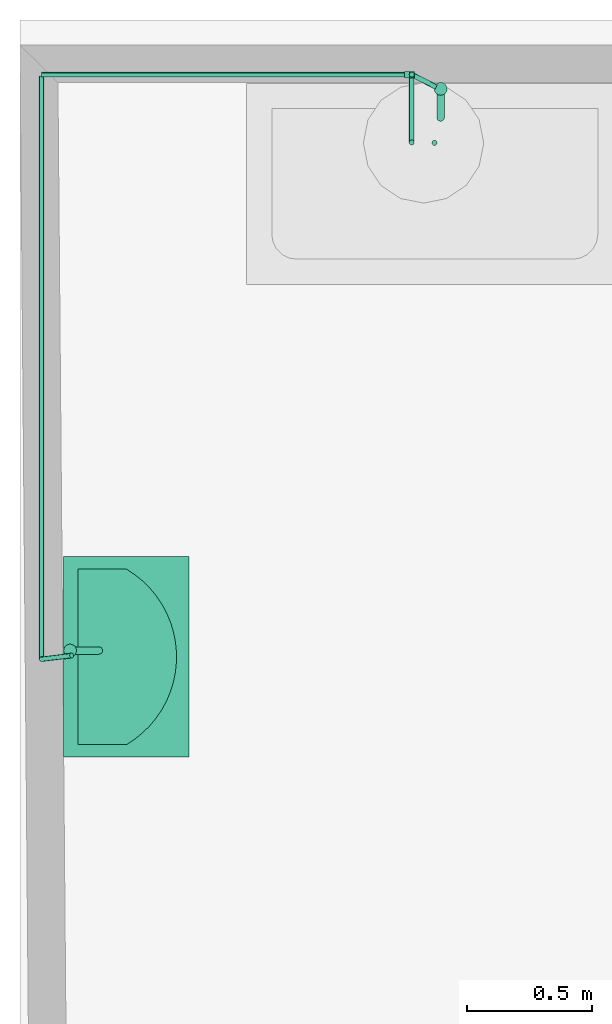
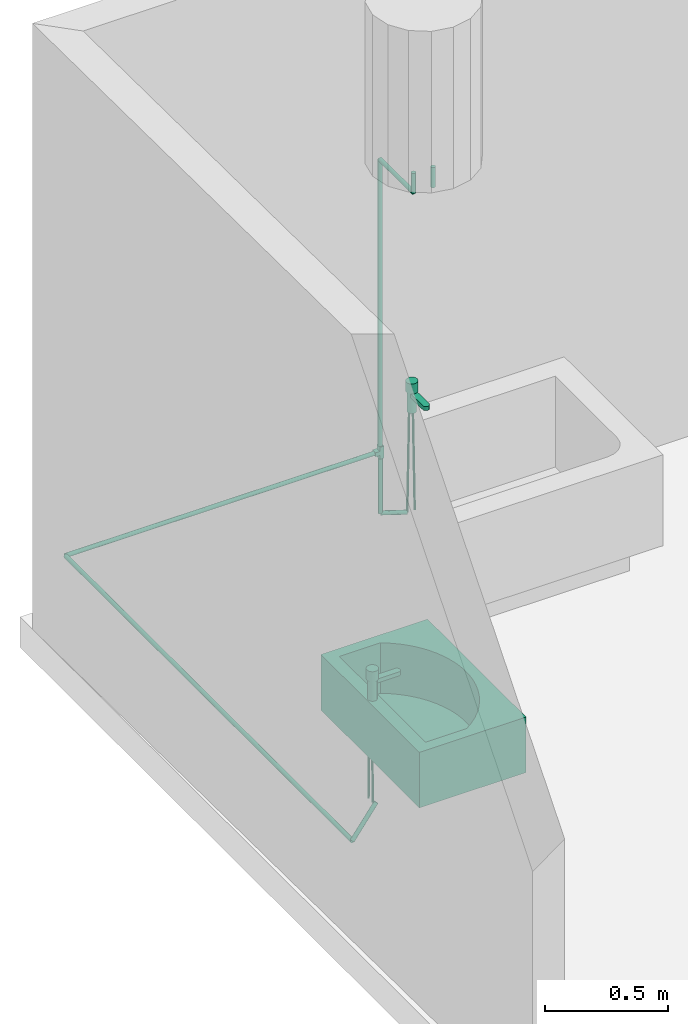
# One storey, part 2 of 3: 9 pipe segments, 2 valves, 1 pipe fitting, 1 sanitary terminal.
"""IFC4 building model written with IfcOpenShell, lengths in metres."""

from ifc_helpers import new_model, entity, si_unit, converted_unit, frame, frame_2d, origin_with_axes, origin_2d, origin_2d_with_axis, place, context, subcontext, project, spatial, line, arc, indexed_curve, circle_curve, circle, outline, extrude, source, transform, mapped, material, material_profile, profile_set, profile_usage, type_object, type_shapes, element, save


model = new_model("IFC4")

# Units and contexts
model_context = context("Model", 3, precision=1e-05, world=origin_with_axes())
plan_context = context("Plan", 2, precision=1e-05, world=origin_2d_with_axis())
body_context = subcontext(model_context, "Body", "Model", "MODEL_VIEW")
ifc_project = project(units=[converted_unit("PLANEANGLEUNIT", "degree", entity("IfcReal", 0.0174532925199433), si_unit("PLANEANGLEUNIT", "RADIAN"), dimensions=[0, 0, 0, 0, 0, 0, 0]), si_unit("AREAUNIT", "SQUARE_METRE"), si_unit("VOLUMEUNIT", "CUBIC_METRE"), si_unit("LENGTHUNIT", "METRE")], contexts=[model_context, plan_context])

# Site, building, storey
site_placement = place(None, origin_with_axes())
site = spatial("IfcSite", under=ifc_project, at=site_placement)
building_placement = place(site_placement, origin_with_axes())
building = spatial("IfcBuilding", under=site, at=building_placement, Name="Building")
storey_placement = place(building_placement, origin_with_axes())
storey = spatial("IfcBuildingStorey", under=building, at=storey_placement, Name="Storey")

# Sanitary terminal
sanitary_terminal_type = type_object("IfcSanitaryTerminalType", Name="BAS-01", PredefinedType="WASHHANDBASIN")
shared_shape_1 = source(origin_with_axes(), body_context, "Body", "SweptSolid", [
    extrude(outline(indexed_curve([(0.0, 0.0), (0.5, 0.0), (0.5, 0.800000011920929), (0.0, 0.800000011920929), (0.0, 0.0)]), holes=[indexed_curve([(0.0579999983310699, 0.750000059604645), (0.0579999983310699, 0.0500000007450581), (0.25, 0.0500000007450581), (0.449999988079071, 0.400000035762787), (0.25, 0.750000059604645)], segments=[line(1, 2), line(2, 3), arc(3, 4, 5), line(5, 1)])]), origin_with_axes(), (0.0, 0.0, 1.0), 0.25),
    extrude(outline(indexed_curve([(0.0, 0.800000071525574), (0.5, 0.800000071525574), (0.5, 0.0), (0.0, 0.0), (0.0, 0.800000071525574)])), frame((1.49011611938477e-08, 0.0, -0.0249999761581421), z_axis=(0.0, 0.0, 1.0), x_axis=(1.0, 0.0, 0.0)), (0.0, 0.0, 1.0), 0.025000000372529),
])
type_shapes(sanitary_terminal_type, [shared_shape_1])
sanitary_terminal_placement = place(storey_placement, frame((0.174114212393761, 1.16106617450714, 0.800000011920929), z_axis=(0.0, 0.0, 1.0), x_axis=(1.0, 0.0, 0.0)))
element("IfcSanitaryTerminal", 1, at=sanitary_terminal_placement, inside=storey, type_object=sanitary_terminal_type, Name="BAS-01", context=body_context, shape_type="MappedRepresentation", body=[
    mapped(shared_shape_1, transform((0.0, 0.0, 0.0), x_axis=(1.0, 0.0, 0.0), y_axis=(0.0, 1.0, 0.0), z_axis=(0.0, 0.0, 1.0), scale=1.0)),
])

# Valves
valve_type = type_object("IfcValveType", Name="MIX-40", PredefinedType="FAUCET")
shared_shape_2 = source(origin_with_axes(), body_context, "Body", "SweptSolid", [
    extrude(outline(circle_curve(frame_2d((1.49011611938477e-08, 0.0)), 0.0199999808298798)), frame((-5.59091567993164e-05, 0.000753998756408691, 0.0), z_axis=(0.0, 0.0, 1.0), x_axis=(1.0, 0.0, 0.0)), (0.0, 0.0, 1.0), 0.100000001490116),
    extrude(outline(indexed_curve([(0.00324422121047974, 0.00130987167358398), (0.0117492079734802, 0.0163098722696304), (0.00324422121047974, 0.0313098728656769), (0.103244222700596, 0.0313098728656769), (0.118292987346649, 0.0163098722696304), (0.103244222700596, 0.00130987167358398)], segments=[arc(1, 2, 3), line(3, 4), arc(4, 5, 6), line(6, 1)])), frame((0.010841965675354, -0.0155558586120605, 0.0799999237060547), z_axis=(0.0, 0.0, 1.0), x_axis=(1.0, 0.0, 0.0)), (0.0, 0.0, 1.0), 0.0199999995529652),
    extrude(outline(circle_curve(frame_2d((1.90300948332833e-08, 0.0)), 0.0255417361909336)), frame((-5.59091567993164e-05, 0.000753998756408691, 0.0999999046325684), z_axis=(0.0, 0.0, 1.0), x_axis=(1.0, 0.0, 0.0)), (0.0, 0.0, 1.0), 0.0500000007450581),
    extrude(outline(circle_curve(origin_2d(), 0.00499999520746994)), frame((-0.00792002760123145, 0.0188064571733357, -0.499757409095764), z_axis=(6.86853392448463e-10, -0.0174524057656526, 0.999847710132599), x_axis=(0.99999999999999, 2.38418571996135e-07, 3.4746536758945e-09)), (0.0, 0.0, 1.0), 0.5),
    extrude(outline(circle_curve(origin_2d(), 0.00499999520746994)), frame((-0.00792002607290776, -0.0161575082426189, -0.499989211559296), z_axis=(-3.9132113163285e-09, 0.0174524057656525, 0.999847710132599), x_axis=(0.99999999999999, 2.38418571996135e-07, -2.47804332609292e-10)), (0.0, 0.0, 1.0), 0.5),
])
type_shapes(valve_type, [shared_shape_2])
for number, where, z_axis, x_axis, name in (
    (2, (0.199711859226227, 1.58566761016846, 1.04999995231628), (0.0, 0.0, 1.0), (1.0, 0.0, 0.0), "MIX-40"),
    (3, (1.67619979381561, 3.82538795471191, 0.599903702735901), (0.0, 0.0, 1.0), (7.54979012640431e-08, -0.999999999999997, 0.0), "MIX-40"),
):
    element("IfcValve", number, at=place(storey_placement, frame(where, z_axis=z_axis, x_axis=x_axis)), inside=storey, type_object=valve_type, Name=name, context=body_context, shape_type="MappedRepresentation", body=[
        mapped(shared_shape_2, transform((0.0, 0.0, 0.0), x_axis=(1.0, 0.0, 0.0), y_axis=(0.0, 1.0, 0.0), z_axis=(0.0, 0.0, 1.0), scale=1.0)),
    ])

# Pipe segments
ifc_material_1 = material(Name="PPE-20H", Category="plumbing")
ifc_material_profile_1 = material_profile(ifc_material_1, circle(Radius=0.00999999977648258, kind="CURVE"))
ifc_profile_set_1 = profile_set([ifc_material_profile_1])
ifc_profile_usage_1 = profile_usage(ifc_profile_set_1, cardinal=5)
pipe_segment_type_1 = type_object("IfcPipeSegmentType", Name="PIP-20H", PredefinedType="RIGIDSEGMENT", material=ifc_profile_set_1)
pipe_segment_1_placement = place(storey_placement, frame((1.56147718429565, 3.6121072769165, 1.95161426067352), z_axis=(-8.74227907843299e-08, -8.74227694680478e-08, -0.999999999999992), x_axis=(-0.999999999999992, 8.74227765734752e-08, 8.74227765734752e-08)))
element("IfcPipeSegment", 4, at=pipe_segment_1_placement, inside=storey, type_object=pipe_segment_type_1, material=ifc_profile_usage_1, Name="20", context=body_context, shape_type="SweptSolid", body=[
    extrude(circle(Radius=0.00999999977648258, kind="CURVE"), origin_with_axes(), (0.0, 0.0, 1.0), 0.100000022165475),
])
ifc_profile_usage_2 = profile_usage(ifc_profile_set_1, cardinal=5)
pipe_segment_2_placement = place(storey_placement, frame((1.56147718429565, 3.6121072769165, 1.85161423683167), z_axis=(-8.74227765734753e-08, 0.999999999999993, 7.54979012640428e-08), x_axis=(-0.999999999999992, -8.74227765734752e-08, 8.74227836789026e-08)))
element("IfcPipeSegment", 5, at=pipe_segment_2_placement, inside=storey, type_object=pipe_segment_type_1, material=ifc_profile_usage_2, Name="20", context=body_context, shape_type="SweptSolid", body=[
    extrude(circle(Radius=0.00999999977648258, kind="CURVE"), origin_with_axes(), (0.0, 0.0, 1.0), 0.269999981081044),
])
ifc_profile_usage_3 = profile_usage(ifc_profile_set_1, cardinal=5)
pipe_segment_3_placement = place(storey_placement, frame((1.56147718429565, 3.88210725784302, 1.85161423683167), z_axis=(-1.50995802528084e-07, -8.74227836789019e-08, -0.999999999999985), x_axis=(-0.999999999999985, 8.74227836789019e-08, 1.50995802528084e-07)))
element("IfcPipeSegment", 6, at=pipe_segment_3_placement, inside=storey, type_object=pipe_segment_type_1, material=ifc_profile_usage_3, Name="20", context=body_context, shape_type="SweptSolid", body=[
    extrude(circle(Radius=0.00999999977648258, kind="CURVE"), origin_with_axes(), (0.0, 0.0, 1.0), 1.41566730292909),
])
ifc_profile_usage_4 = profile_usage(ifc_profile_set_1, cardinal=5)
pipe_segment_4_placement = place(storey_placement, frame((1.56292796134949, 3.88210701942444, 0.10009765625), z_axis=(0.889495304304371, -0.456941510654187, -0.00159983172349935), x_axis=(0.456942106713704, 0.889496436818064, -9.80800568786743e-08)))
element("IfcPipeSegment", 7, at=pipe_segment_4_placement, inside=storey, type_object=pipe_segment_type_1, material=ifc_profile_usage_4, Name="20", context=body_context, shape_type="SweptSolid", body=[
    extrude(circle(Radius=0.00999999977648258, kind="CURVE"), origin_with_axes(), (0.0, 0.0, 1.0), 0.108570010969913),
])
ifc_profile_usage_5 = profile_usage(ifc_profile_set_1, cardinal=5)
pipe_segment_5_placement = place(storey_placement, frame((1.53292798995972, 3.8821074962616, 0.405375480651855), z_axis=(-0.999999999999994, -7.54978941586155e-08, 7.54979012640429e-08), x_axis=(7.5497901264043e-08, -0.999999999999995, 5.96046234591083e-08)))
element("IfcPipeSegment", 8, at=pipe_segment_5_placement, inside=storey, type_object=pipe_segment_type_1, material=ifc_profile_usage_5, Name="20", context=body_context, shape_type="SweptSolid", body=[
    extrude(circle(Radius=0.00999999977648258, kind="CURVE"), origin_with_axes(), (0.0, 0.0, 1.0), 1.44729939574508),
])
ifc_profile_usage_6 = profile_usage(ifc_profile_set_1, cardinal=5)
pipe_segment_6_placement = place(storey_placement, frame((0.0856286361813545, 3.87642645835876, 0.407073020935059), z_axis=(0.0, -0.999999999999997, 7.54979012640431e-08), x_axis=(1.0, 0.0, 0.0)))
element("IfcPipeSegment", 9, at=pipe_segment_6_placement, inside=storey, type_object=pipe_segment_type_1, material=ifc_profile_usage_6, Name="20", context=body_context, shape_type="SweptSolid", body=[
    extrude(circle(Radius=0.00999999977648258, kind="CURVE"), origin_with_axes(), (0.0, 0.0, 1.0), 2.3255155135404),
])
ifc_profile_usage_7 = profile_usage(ifc_profile_set_1, cardinal=5)
pipe_segment_7_placement = place(storey_placement, frame((0.205741360783577, 1.56657183170319, 0.547182261943817), z_axis=(-0.650124304096081, -0.08039343266184, -0.755562892953613), x_axis=(0.122723668943666, -0.992440880395902, 1.15434048220236e-07)))
element("IfcPipeSegment", 10, at=pipe_segment_7_placement, inside=storey, type_object=pipe_segment_type_1, material=ifc_profile_usage_7, Name="20", context=body_context, shape_type="SweptSolid", body=[
    extrude(circle(Radius=0.00999999977648258, kind="CURVE"), origin_with_axes(), (0.0, 0.0, 1.0), 0.185436660884796),
])
ifc_profile_usage_8 = profile_usage(ifc_profile_set_1, cardinal=5)
pipe_segment_8_placement = place(storey_placement, frame((1.56292796134949, 3.88210701942444, 0.375375598669052), z_axis=(-8.74227907843299e-08, -8.74227694680478e-08, -0.999999999999992), x_axis=(-0.999999999999992, 8.74227765734752e-08, 8.74227765734752e-08)))
element("IfcPipeSegment", 11, at=pipe_segment_8_placement, inside=storey, type_object=pipe_segment_type_1, material=ifc_profile_usage_8, Name="20", context=body_context, shape_type="SweptSolid", body=[
    extrude(circle(Radius=0.00999999977648258, kind="CURVE"), origin_with_axes(), (0.0, 0.0, 1.0), 0.275277946633361),
])

# Pipe fitting
pipe_fitting_type = type_object("IfcPipeFittingType", Name="TEE-20", PredefinedType="JUNCTION")
shared_shape_3 = source(origin_with_axes(), body_context, "Body", "SweptSolid", [
    extrude(outline(indexed_curve([(-0.0103197023272514, -0.0881810039281845), (0.00968027301132679, -0.0881812572479248), (0.00968026835471392, -0.10818100720644), (0.0296803303062916, -0.10818100720644), (0.0296803303062916, -0.128181263804436), (-0.0303196869790554, -0.128181263804436), (-0.0303196869790554, -0.10818100720644), (-0.0103196920827031, -0.10818100720644), (-0.0103197023272514, -0.0881810039281845)])), frame((0.0, 0.128580808639526, 0.0), z_axis=(0.0, 0.0, 1.0), x_axis=(1.0, 0.0, 0.0)), (0.0, 0.0, 1.0), 0.025000000372529),
])
type_shapes(pipe_fitting_type, [shared_shape_3])
pipe_fitting_placement = place(storey_placement, frame((1.57332766056061, 3.86960697174072, 0.405055940151215), z_axis=(-4.37113882867379e-08, 0.999999999999999, -3.30011807777566e-15), x_axis=(7.54979012640431e-08, 0.0, -0.999999999999997)))
element("IfcPipeFitting", 12, at=pipe_fitting_placement, inside=storey, type_object=pipe_fitting_type, Name="TEE-20", context=body_context, shape_type="MappedRepresentation", body=[
    mapped(shared_shape_3, transform((0.0, 0.0, 0.0), x_axis=(1.0, 0.0, 0.0), y_axis=(0.0, 1.0, 0.0), z_axis=(0.0, 0.0, 1.0), scale=1.0)),
])

# Pipe segment
ifc_material_2 = material(Name="PPE-20C", Category="plumbing")
ifc_material_profile_2 = material_profile(ifc_material_2, circle(Radius=0.00999999977648258, kind="CURVE"))
ifc_profile_set_2 = profile_set([ifc_material_profile_2])
ifc_profile_usage_9 = profile_usage(ifc_profile_set_2)
pipe_segment_type_2 = type_object("IfcPipeSegmentType", Name="PIP-20C", PredefinedType="RIGIDSEGMENT", material=ifc_profile_set_2)
pipe_segment_9_placement = place(storey_placement, frame((1.65232241153717, 3.61012315750122, 1.94999992847443), z_axis=(-8.74227907843299e-08, -8.74227694680478e-08, -0.999999999999992), x_axis=(-0.999999999999992, 8.74227765734752e-08, 8.74227765734752e-08)))
element("IfcPipeSegment", 13, at=pipe_segment_9_placement, inside=storey, type_object=pipe_segment_type_2, material=ifc_profile_usage_9, Name="20C", context=body_context, shape_type="SweptSolid", body=[
    extrude(circle(Radius=0.00999999977648258, kind="CURVE"), origin_with_axes(), (0.0, 0.0, 1.0), 0.100000022165475),
])

save(model, "model.ifc")
